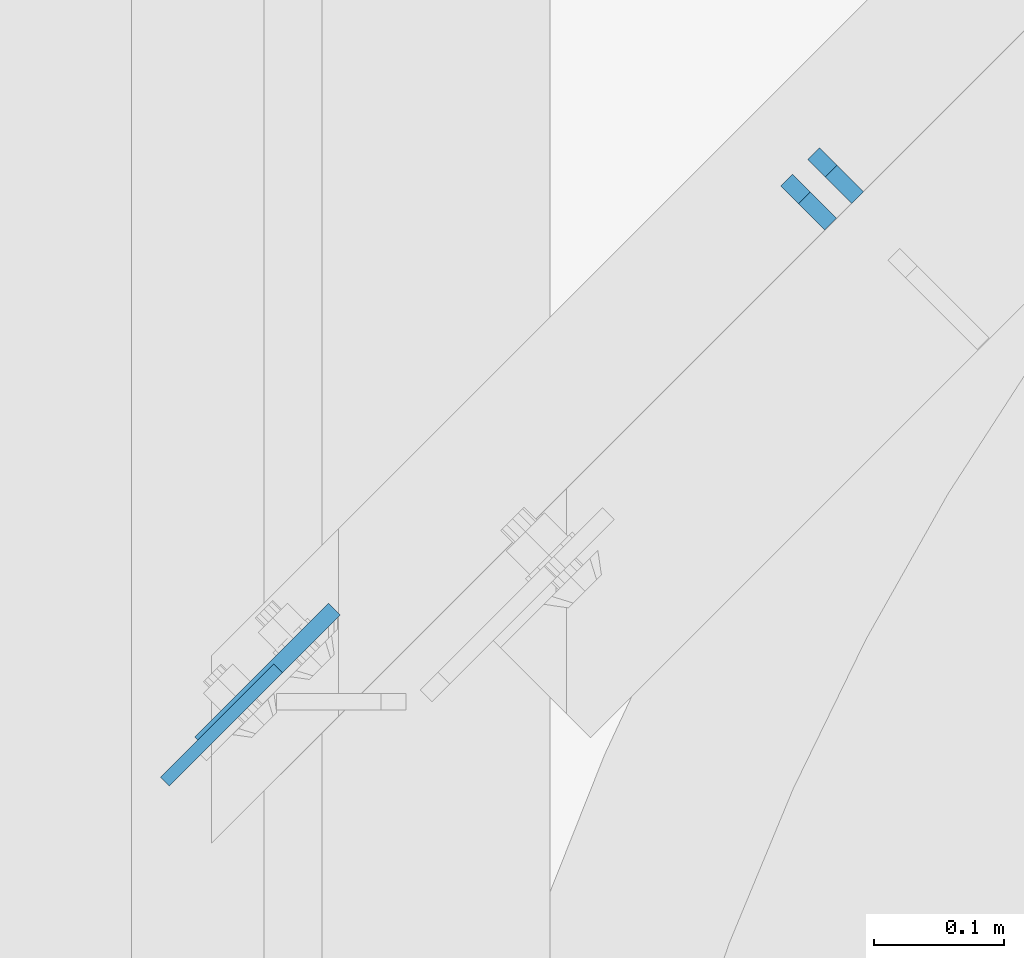
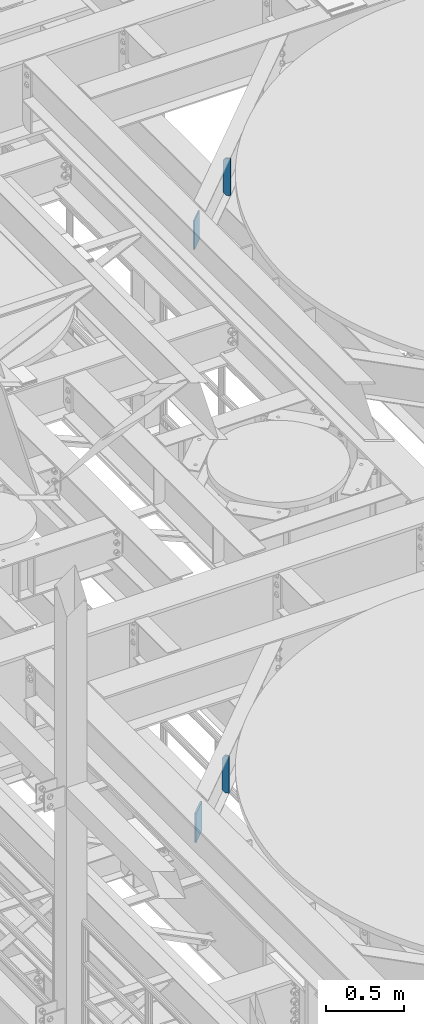
# One storey, part 1540 of 1876: 4 plates, 4 elements without a shape of their own.
"""IFC2X3 building model written with IfcOpenShell, lengths in millimetres."""

from ifc_helpers import new_model, si_unit, frame, origin_with_axes, place, context, subcontext, project, spatial, faceted_brep, material, type_object, element, aggregate, save


model = new_model("IFC2X3")

# Units and contexts
model_context = context("Model", 3, precision=1e-05, world=origin_with_axes())
body_context = subcontext(model_context, "Body", "Model", "MODEL_VIEW")
ifc_project = project(units=[si_unit("LENGTHUNIT", "METRE", prefix="MILLI"), si_unit("AREAUNIT", "SQUARE_METRE"), si_unit("VOLUMEUNIT", "CUBIC_METRE"), si_unit("MASSUNIT", "GRAM", prefix="KILO"), si_unit("TIMEUNIT", "SECOND"), si_unit("PLANEANGLEUNIT", "RADIAN"), si_unit("SOLIDANGLEUNIT", "STERADIAN"), si_unit("THERMODYNAMICTEMPERATUREUNIT", "DEGREE_CELSIUS"), si_unit("LUMINOUSINTENSITYUNIT", "LUMEN")], contexts=[model_context])

# Site, building, storey
site_placement = place(None, origin_with_axes())
site = spatial("IfcSite", under=ifc_project, at=site_placement, CompositionType="ELEMENT")
building_placement = place(site_placement, origin_with_axes())
building = spatial("IfcBuilding", under=site, at=building_placement, Name="Undefined", CompositionType="ELEMENT")
storey_placement = place(building_placement, origin_with_axes())
storey = spatial("IfcBuildingStorey", under=building, at=storey_placement, Name="Undefined", CompositionType="ELEMENT", Elevation=0.0)

# Assembly, plate
assembly_1_placement = place(storey_placement, origin_with_axes())
assembly_1 = element("IfcElementAssembly", 1, at=assembly_1_placement, inside=storey, Name="BEAM", AssemblyPlace="NOTDEFINED", PredefinedType="RIGID_FRAME")
ifc_material = material(Name="STEEL/A36")
plate_type_1 = type_object("IfcPlateType", PredefinedType="NOTDEFINED")
plate_1_placement = place(assembly_1_placement, frame((2006.79248257337, -649.240286388131, 17945.1), z_axis=(0.707106781186548, 0.707106781186547, 0.0), x_axis=(0.0, 0.0, -1.0)))
plate_1 = element("IfcPlate", 2, at=plate_1_placement, type_object=plate_type_1, material=ifc_material, Name="PLATE", context=body_context, shape_type="Brep", body=[
    faceted_brep([(0.0, -4.76249999999982, 0.0), (0.0, -4.76249999998612, 122.735511779807), (0.0, 4.76250000001534, 122.735511779805), (0.0, 4.76249999999982, 0.0), (228.600006103516, -4.76249999998612, 122.735511779807), (228.600006103516, 4.76250000001534, 122.735511779805), (228.600006103516, -4.76250000000073, 0.0), (228.600006103516, 4.76250000000073, 0.0)], [[[0, 1, 2, 3]], [[1, 4, 5, 2]], [[4, 6, 7, 5]], [[6, 0, 3, 7]], [[5, 7, 3, 2]], [[6, 4, 1, 0]]]),
])
aggregate(assembly_1, [plate_1])

assembly_2_placement = place(storey_placement, origin_with_axes())
assembly_2 = element("IfcElementAssembly", 3, at=assembly_2_placement, inside=storey, Name="BEAM", AssemblyPlace="NOTDEFINED", PredefinedType="RIGID_FRAME")
plate_type_2 = type_object("IfcPlateType", PredefinedType="NOTDEFINED")
plate_2_placement = place(assembly_2_placement, frame((2537.91930108065, -201.180824470226, 17684.75), z_axis=(0.0, 0.0, 1.0), x_axis=(-0.707106781186548, 0.707106781186547, 0.0)))
plate_2 = element("IfcPlate", 4, at=plate_2_placement, type_object=plate_type_2, material=ifc_material, Name="PLATE", context=body_context, shape_type="Brep", body=[
    faceted_brep([(0.0, -6.35000000000036, 0.0), (-1.13686837721616e-12, -6.35000000000082, 292.100006103516), (1.13686837721616e-12, 6.35000000000105, 292.100006103516), (0.0, 6.35000000000036, 0.0), (28.5750007629385, -6.35000000000014, 292.100006103516), (28.5750007629406, 6.35000000000173, 292.100006103516), (47.6249999999993, -6.34999999999968, 273.050006866455), (47.6250000000014, 6.35000000000218, 273.050006866455), (47.6249999999993, -6.34999999999968, 19.0499992370605), (47.6250000000014, 6.35000000000218, 19.0499992370605), (28.5750007629385, -6.35000000000014, 0.0), (28.5750007629406, 6.35000000000173, 0.0)], [[[0, 1, 2, 3]], [[1, 4, 5, 2]], [[4, 6, 7, 5]], [[6, 8, 9, 7]], [[8, 10, 11, 9]], [[10, 0, 3, 11]], [[5, 7, 9, 11, 3, 2]], [[10, 8, 6, 4, 1, 0]]]),
])
aggregate(assembly_2, [plate_2])

assembly_3_placement = place(storey_placement, origin_with_axes())
assembly_3 = element("IfcElementAssembly", 5, at=assembly_3_placement, inside=storey, Name="BEAM", AssemblyPlace="NOTDEFINED", PredefinedType="RIGID_FRAME")
plate_3_placement = place(assembly_3_placement, frame((2517.15432224266, -221.690243261806, 13011.15), z_axis=(0.0, 0.0, 1.0), x_axis=(-0.707106781186548, 0.707106781186547, 0.0)))
plate_3 = element("IfcPlate", 6, at=plate_3_placement, type_object=plate_type_2, material=ifc_material, Name="PLATE", context=body_context, shape_type="Brep", body=[
    faceted_brep([(0.0, -6.35000000000036, 0.0), (-1.13686837721616e-12, -6.35000000000082, 292.100006103516), (1.13686837721616e-12, 6.35000000000105, 292.100006103516), (0.0, 6.35000000000036, 0.0), (28.5750007629385, -6.35000000000014, 292.100006103516), (28.5750007629406, 6.35000000000173, 292.100006103516), (47.6249999999941, -6.35000000000491, 266.700006484985), (47.6249999999939, 6.34999999999445, 266.700006484985), (47.6249999999993, -6.34999999999968, 19.0499992370605), (47.6250000000014, 6.35000000000218, 19.0499992370605), (28.5750007629385, -6.35000000000014, 0.0), (28.5750007629406, 6.35000000000173, 0.0)], [[[0, 1, 2, 3]], [[1, 4, 5, 2]], [[4, 6, 7, 5]], [[6, 8, 9, 7]], [[8, 10, 11, 9]], [[10, 0, 3, 11]], [[5, 7, 9, 11, 3, 2]], [[10, 8, 6, 4, 1, 0]]]),
])
aggregate(assembly_3, [plate_3])

assembly_4_placement = place(storey_placement, origin_with_axes())
assembly_4 = element("IfcElementAssembly", 7, at=assembly_4_placement, inside=storey, Name="BEAM", AssemblyPlace="NOTDEFINED", PredefinedType="RIGID_FRAME")
plate_type_3 = type_object("IfcPlateType", PredefinedType="NOTDEFINED")
plate_4_placement = place(assembly_4_placement, frame((2034.10915829953, -619.422848248856, 13258.8), z_axis=(0.707106781186548, 0.707106781186547, 0.0), x_axis=(0.0, 0.0, -1.0)))
plate_4 = element("IfcPlate", 8, at=plate_4_placement, type_object=plate_type_3, material=ifc_material, Name="PLATE", context=body_context, shape_type="Brep", body=[
    faceted_brep([(0.0, -6.35000000000036, 0.0), (0.0, -6.35000000006039, 144.960510253931), (0.0, 6.34999999993761, 144.960510253933), (0.0, 6.35000000000036, 0.0), (228.600006103516, -6.35000000006039, 144.960510253931), (228.600006103516, 6.34999999993761, 144.960510253933), (228.600006103516, -6.34999999999854, 0.0), (228.600006103516, 6.34999999999854, 0.0)], [[[0, 1, 2, 3]], [[1, 4, 5, 2]], [[4, 6, 7, 5]], [[6, 0, 3, 7]], [[5, 7, 3, 2]], [[6, 4, 1, 0]]]),
])
aggregate(assembly_4, [plate_4])

save(model, "model.ifc")
